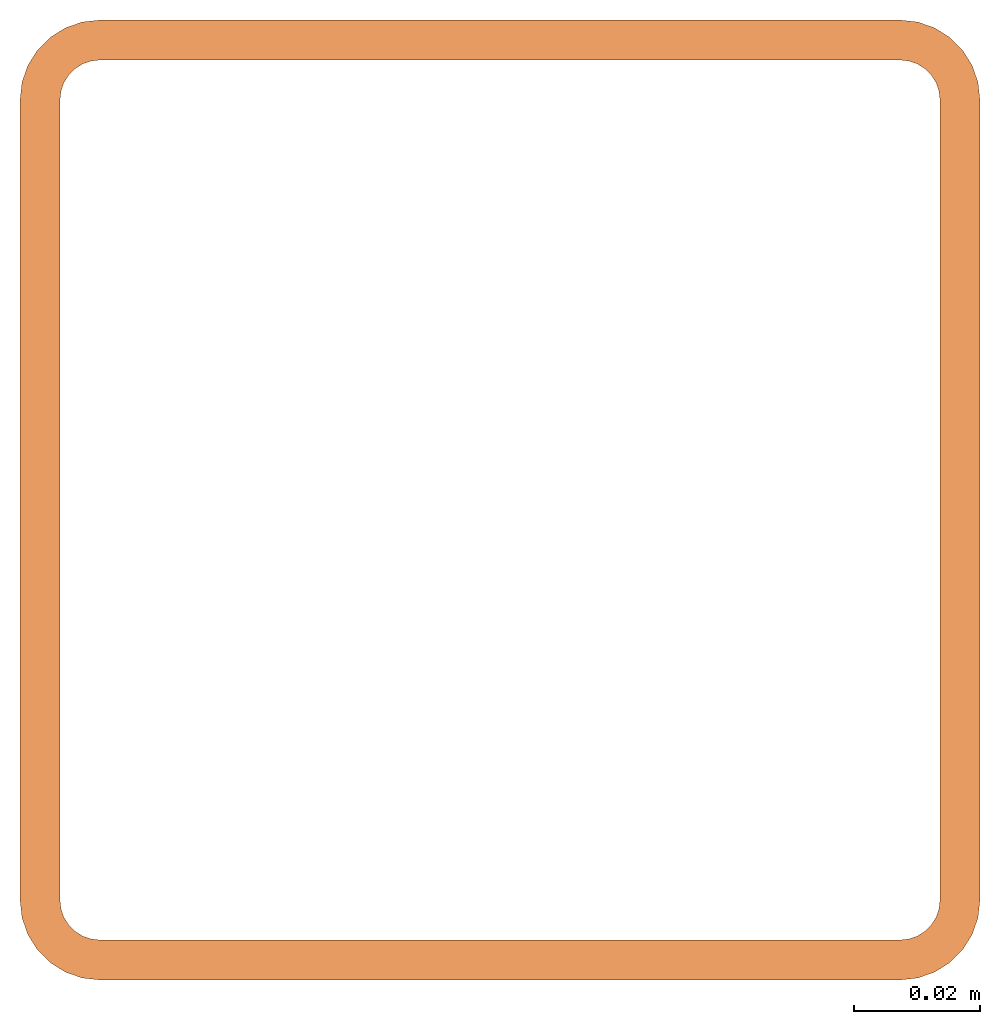
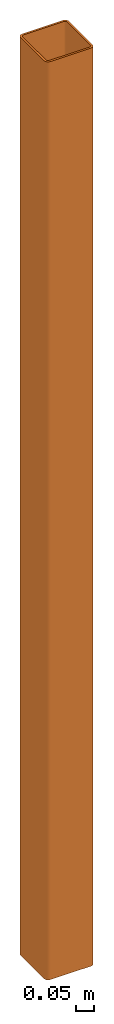
# One storey: 1 proxy.
"""IFC2X3 building model written with IfcOpenShell, lengths in feet."""

from ifc_helpers import new_model, entity, si_unit, converted_unit, derived_unit, direction, frame, frame_2d, origin, place, context, subcontext, project, spatial, polyline, circle_curve, parameter, trimmed, segment, composite_curve, outline, extrude, source, transform, mapped, type_object, type_shapes, element, save


model = new_model("IFC2X3")

# Units and contexts
model_context = context("Model", 3, precision=0.0001, world=origin(), true_north=direction((6.12303176911189e-17, 1.0)))
body_context = subcontext(model_context, "Body", "Model", "MODEL_VIEW")
ifc_project = project(units=[converted_unit("LENGTHUNIT", "FOOT", entity("IfcRatioMeasure", 0.3048), si_unit("LENGTHUNIT", "METRE"), dimensions=[1, 0, 0, 0, 0, 0, 0]), converted_unit("AREAUNIT", "SQUARE FOOT", entity("IfcRatioMeasure", 0.09290304), si_unit("AREAUNIT", "SQUARE_METRE"), dimensions=[2, 0, 0, 0, 0, 0, 0]), converted_unit("VOLUMEUNIT", "CUBIC FOOT", entity("IfcRatioMeasure", 0.028316846592), si_unit("VOLUMEUNIT", "CUBIC_METRE"), dimensions=[3, 0, 0, 0, 0, 0, 0]), converted_unit("PLANEANGLEUNIT", "DEGREE", entity("IfcRatioMeasure", 0.0174532925199433), si_unit("PLANEANGLEUNIT", "RADIAN"), dimensions=[0, 0, 0, 0, 0, 0, 0]), si_unit("MASSUNIT", "GRAM", prefix="KILO"), derived_unit("MASSDENSITYUNIT", [(si_unit("MASSUNIT", "GRAM", prefix="KILO"), 1), (si_unit("LENGTHUNIT", "METRE"), -3)]), si_unit("TIMEUNIT", "SECOND"), si_unit("FREQUENCYUNIT", "HERTZ"), si_unit("THERMODYNAMICTEMPERATUREUNIT", "DEGREE_CELSIUS"), derived_unit("THERMALTRANSMITTANCEUNIT", [(si_unit("MASSUNIT", "GRAM", prefix="KILO"), 1), (si_unit("THERMODYNAMICTEMPERATUREUNIT", "KELVIN"), -1), (si_unit("TIMEUNIT", "SECOND"), -3)]), derived_unit("VOLUMETRICFLOWRATEUNIT", [(si_unit("LENGTHUNIT", "METRE"), 3), (si_unit("TIMEUNIT", "SECOND"), -1)]), si_unit("ELECTRICCURRENTUNIT", "AMPERE"), si_unit("ELECTRICVOLTAGEUNIT", "VOLT"), si_unit("POWERUNIT", "WATT"), si_unit("FORCEUNIT", "NEWTON"), si_unit("ILLUMINANCEUNIT", "LUX"), si_unit("LUMINOUSFLUXUNIT", "LUMEN"), si_unit("LUMINOUSINTENSITYUNIT", "CANDELA"), derived_unit("USERDEFINED", [(si_unit("MASSUNIT", "GRAM", prefix="KILO"), -1), (si_unit("LENGTHUNIT", "METRE"), -2), (si_unit("TIMEUNIT", "SECOND"), 3), (si_unit("LUMINOUSFLUXUNIT", "LUMEN"), 1)]), derived_unit("LINEARVELOCITYUNIT", [(si_unit("LENGTHUNIT", "METRE"), 1), (si_unit("TIMEUNIT", "SECOND"), -1)]), si_unit("PRESSUREUNIT", "PASCAL"), derived_unit("USERDEFINED", [(si_unit("LENGTHUNIT", "METRE"), -2), (si_unit("MASSUNIT", "GRAM", prefix="KILO"), 1), (si_unit("TIMEUNIT", "SECOND"), -2)]), derived_unit("LINEARFORCEUNIT", [(si_unit("MASSUNIT", "GRAM", prefix="KILO"), 1), (si_unit("LENGTHUNIT", "METRE"), 1), (si_unit("TIMEUNIT", "SECOND"), -2), (si_unit("LENGTHUNIT", "METRE"), -1)]), derived_unit("PLANARFORCEUNIT", [(si_unit("MASSUNIT", "GRAM", prefix="KILO"), 1), (si_unit("LENGTHUNIT", "METRE"), 1), (si_unit("TIMEUNIT", "SECOND"), -2), (si_unit("LENGTHUNIT", "METRE"), -2)])], contexts=[model_context])

# Site, building, storey
site_placement = place(None, origin())
site = spatial("IfcSite", under=ifc_project, at=site_placement, CompositionType="ELEMENT")
building_placement = place(site_placement, origin())
building = spatial("IfcBuilding", under=site, at=building_placement, CompositionType="ELEMENT")
storey_placement = place(building_placement, origin())
storey = spatial("IfcBuildingStorey", under=building, at=storey_placement, Name="Level 1", CompositionType="ELEMENT", Elevation=0.0)

# Proxy
building_element_proxy_type = type_object("IfcBuildingElementProxyType", Name="Generic Models 1:Generic Models 1", PredefinedType="NOTDEFINED")
shared_shape = source(origin(), body_context, "Body", "SweptSolid", [
    extrude(outline(composite_curve([segment(polyline([(-0.208333333333333, -0.25), (0.208333333333333, -0.25)]), True, "CONTINUOUS"), segment(trimmed(circle_curve(frame_2d((0.208333333333333, -0.208333333333333), x_axis=(-1.0, 0.0)), 0.0416666666666667), [parameter(90.0000000000004)], [parameter(180.0)], True, "PARAMETER"), True, "CONTINUOUS"), segment(polyline([(0.25, -0.208333333333333), (0.25, 0.208333333333333)]), True, "CONTINUOUS"), segment(trimmed(circle_curve(frame_2d((0.208333333333333, 0.208333333333333), x_axis=(-1.0, 0.0)), 0.0416666666666667), [parameter(180.0)], [parameter(270.0)], True, "PARAMETER"), True, "CONTINUOUS"), segment(polyline([(0.208333333333333, 0.25), (-0.208333333333333, 0.25)]), True, "CONTINUOUS"), segment(trimmed(circle_curve(frame_2d((-0.208333333333333, 0.208333333333333), x_axis=(-1.0, 0.0)), 0.0416666666666667), [parameter(270.0)], [parameter(3.56222124323914e-13)], True, "PARAMETER"), True, "CONTINUOUS"), segment(polyline([(-0.25, 0.208333333333333), (-0.25, -0.208333333333334)]), True, "CONTINUOUS"), segment(trimmed(circle_curve(frame_2d((-0.208333333333333, -0.208333333333333), x_axis=(-1.0, 0.0)), 0.0416666666666667), [parameter(3.56222124323914e-13)], [parameter(90.0000000000004)], True, "PARAMETER"), True, "CONTINUOUS")], self_intersect=False), holes=[composite_curve([segment(trimmed(circle_curve(frame_2d((-0.208333333333333, -0.208333333333333), x_axis=(-1.0, 0.0)), 0.0208333333333333), [parameter(1.52666624710249e-13)], [parameter(90.0000000000001)], True, "PARAMETER"), False, "CONTINUOUS"), segment(polyline([(-0.229166666666667, -0.208333333333333), (-0.229166666666667, 0.208333333333333)]), True, "CONTINUOUS"), segment(trimmed(circle_curve(frame_2d((-0.208333333333333, 0.208333333333333), x_axis=(-1.0, 0.0)), 0.0208333333333333), [parameter(270.0)], [parameter(0.0)], True, "PARAMETER"), False, "CONTINUOUS"), segment(polyline([(-0.208333333333333, 0.229166666666667), (0.208333333333333, 0.229166666666667)]), True, "CONTINUOUS"), segment(trimmed(circle_curve(frame_2d((0.208333333333333, 0.208333333333333), x_axis=(-1.0, 0.0)), 0.0208333333333333), [parameter(180.0)], [parameter(270.0)], True, "PARAMETER"), False, "CONTINUOUS"), segment(polyline([(0.229166666666667, 0.208333333333333), (0.229166666666667, -0.208333333333333)]), True, "CONTINUOUS"), segment(trimmed(circle_curve(frame_2d((0.208333333333333, -0.208333333333333), x_axis=(-1.0, 0.0)), 0.0208333333333333), [parameter(90.0000000000001)], [parameter(180.0)], True, "PARAMETER"), False, "CONTINUOUS"), segment(polyline([(0.208333333333333, -0.229166666666667), (-0.208333333333333, -0.229166666666667)]), True, "CONTINUOUS")], self_intersect=False)]), frame((0.0, 0.0, 0.0), z_axis=(0.0, 0.0, 1.0), x_axis=(-1.0, 0.0, 0.0)), (0.0, 0.0, 1.0), 10.0),
])
type_shapes(building_element_proxy_type, [shared_shape])
proxy_placement = place(storey_placement, origin())
element("IfcBuildingElementProxy", 1, at=proxy_placement, inside=storey, type_object=building_element_proxy_type, Name="Generic Models 1:Generic Models 1", ObjectType="Generic Models 1:Generic Models 1", context=body_context, shape_type="MappedRepresentation", body=[
    mapped(shared_shape, transform((0.0, 0.0, 0.0), scale=1.0)),
])

save(model, "model.ifc")
